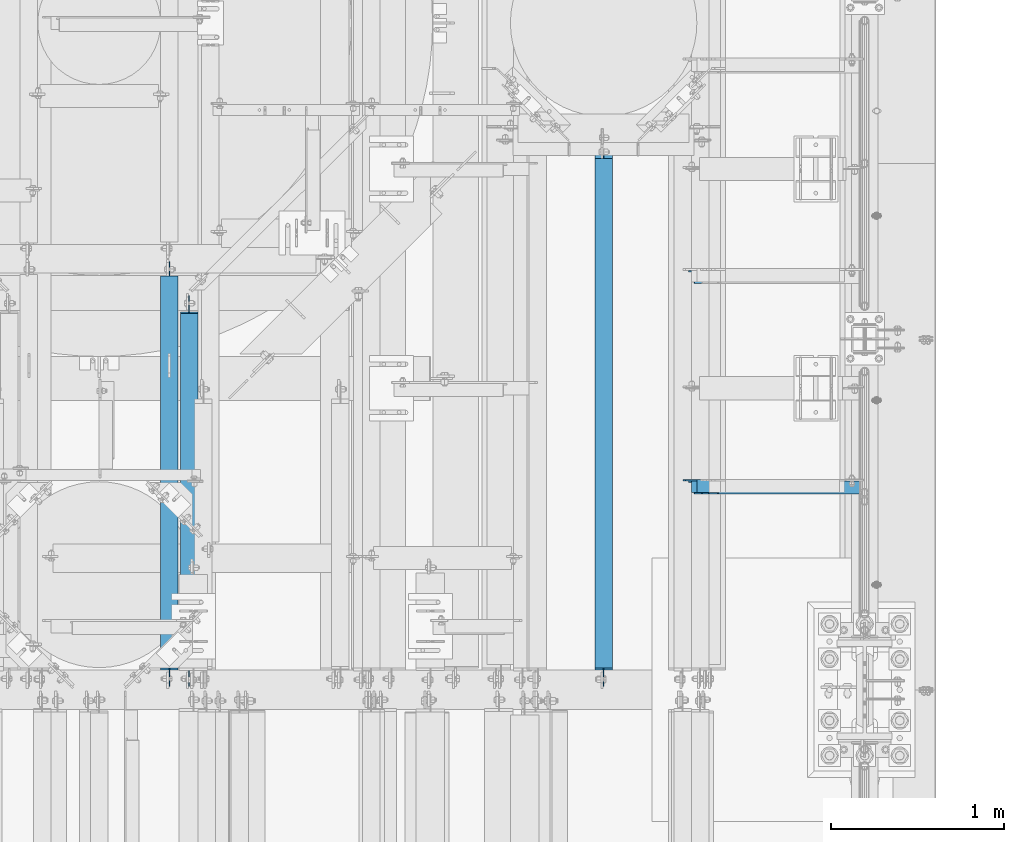
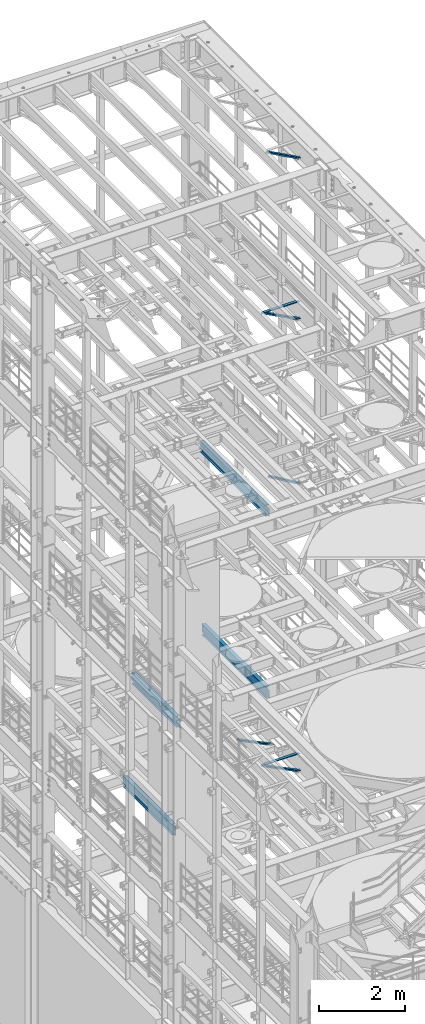
# One storey, part 1047 of 1876: 6 beams, 5 members, 11 elements without a shape of their own.
"""IFC2X3 building model written with IfcOpenShell, lengths in millimetres."""

from ifc_helpers import new_model, si_unit, frame, origin_with_axes, place, context, subcontext, project, spatial, faceted_brep, material, type_object, element, aggregate, save


model = new_model("IFC2X3")

# Units and contexts
model_context = context("Model", 3, precision=1e-05, world=origin_with_axes())
body_context = subcontext(model_context, "Body", "Model", "MODEL_VIEW")
ifc_project = project(units=[si_unit("LENGTHUNIT", "METRE", prefix="MILLI"), si_unit("AREAUNIT", "SQUARE_METRE"), si_unit("VOLUMEUNIT", "CUBIC_METRE"), si_unit("MASSUNIT", "GRAM", prefix="KILO"), si_unit("TIMEUNIT", "SECOND"), si_unit("PLANEANGLEUNIT", "RADIAN"), si_unit("SOLIDANGLEUNIT", "STERADIAN"), si_unit("THERMODYNAMICTEMPERATUREUNIT", "DEGREE_CELSIUS"), si_unit("LUMINOUSINTENSITYUNIT", "LUMEN")], contexts=[model_context])

# Site, building, storey
site_placement = place(None, origin_with_axes())
site = spatial("IfcSite", under=ifc_project, at=site_placement, CompositionType="ELEMENT")
building_placement = place(site_placement, origin_with_axes())
building = spatial("IfcBuilding", under=site, at=building_placement, Name="Undefined", CompositionType="ELEMENT")
storey_placement = place(building_placement, origin_with_axes())
storey = spatial("IfcBuildingStorey", under=building, at=storey_placement, Name="Undefined", CompositionType="ELEMENT", Elevation=0.0)

# Assembly, member
assembly_1_placement = place(storey_placement, origin_with_axes())
assembly_1 = element("IfcElementAssembly", 1, at=assembly_1_placement, inside=storey, AssemblyPlace="NOTDEFINED", PredefinedType="RIGID_FRAME")
ifc_material_1 = material(Name="STEEL/A36")
member_type = type_object("IfcMemberType", Name="L3X3X3/8", PredefinedType="NOTDEFINED")
member_1_placement = place(assembly_1_placement, frame((6546.00359127146, 8791.575, 5110.24886127725), z_axis=(0.0, -1.0, 0.0), x_axis=(0.894904191539842, 0.0, -0.446258319770535)))
member_1 = element("IfcMember", 2, at=member_1_placement, type_object=member_type, material=ifc_material_1, ObjectType="L3X3X3/8", context=body_context, shape_type="Brep", body=[
    faceted_brep([(80.1547206858395, 38.100000000054, -38.1000000000004), (80.1547206858395, 38.100000000054, 38.1000000000004), (1158.95112186373, 38.1000000006807, 38.1000000000004), (1158.95112186373, 38.1000000006807, -38.1000000000004), (80.1547206858399, 28.5750000000526, 38.1000000000004), (1158.95112186373, 28.5750000006792, 38.1000000000004), (80.1547206858399, 28.5750000000526, -28.5750000000007), (1158.95112186373, 28.5750000006792, -28.5750000000007), (80.154720685839, -38.0999999999594, -28.5750000000007), (1158.95112186373, -38.0999999993337, -28.5750000000007), (80.154720685839, -38.0999999999594, -38.1000000000004), (1158.95112186373, -38.0999999993337, -38.1000000000004)], [[[0, 1, 2, 3]], [[1, 4, 5, 2]], [[4, 6, 7, 5]], [[6, 8, 9, 7]], [[8, 10, 11, 9]], [[10, 0, 3, 11]], [[5, 7, 9, 11, 3, 2]], [[10, 8, 6, 4, 1, 0]]]),
])
aggregate(assembly_1, [member_1])

assembly_2_placement = place(storey_placement, origin_with_axes())
assembly_2 = element("IfcElementAssembly", 3, at=assembly_2_placement, inside=storey, AssemblyPlace="NOTDEFINED", PredefinedType="RIGID_FRAME")
member_2_placement = place(assembly_2_placement, frame((6546.00359127146, 10010.775, 5110.24886127725), z_axis=(0.0, -1.0, 0.0), x_axis=(0.894904191539842, 0.0, -0.446258319770535)))
member_2 = element("IfcMember", 4, at=member_2_placement, type_object=member_type, material=ifc_material_1, ObjectType="L3X3X3/8", context=body_context, shape_type="Brep", body=[
    faceted_brep([(80.1547206858395, 38.100000000054, -38.1000000000004), (80.1547206858395, 38.100000000054, 38.1000000000004), (1158.95112186373, 38.1000000006807, 38.1000000000004), (1158.95112186373, 38.1000000006807, -38.1000000000004), (80.1547206858399, 28.5750000000526, 38.1000000000004), (1158.95112186373, 28.5750000006792, 38.1000000000004), (80.1547206858399, 28.5750000000526, -28.5750000000007), (1158.95112186373, 28.5750000006792, -28.5750000000007), (80.154720685839, -38.0999999999594, -28.5750000000007), (1158.95112186373, -38.0999999993337, -28.5750000000007), (80.154720685839, -38.0999999999594, -38.1000000000004), (1158.95112186373, -38.0999999993337, -38.1000000000004)], [[[0, 1, 2, 3]], [[1, 4, 5, 2]], [[4, 6, 7, 5]], [[6, 8, 9, 7]], [[8, 10, 11, 9]], [[10, 0, 3, 11]], [[5, 7, 9, 11, 3, 2]], [[10, 8, 6, 4, 1, 0]]]),
])
aggregate(assembly_2, [member_2])

assembly_3_placement = place(storey_placement, origin_with_axes())
assembly_3 = element("IfcElementAssembly", 5, at=assembly_3_placement, inside=storey, Name="BRACE", AssemblyPlace="NOTDEFINED", PredefinedType="RIGID_FRAME")
member_3_placement = place(assembly_3_placement, frame((6673.56288393271, 8791.575, 13302.1718727092), z_axis=(0.0, -1.0, 0.0), x_axis=(0.861630637805759, 0.0, -0.507535854885584)))
member_3 = element("IfcMember", 6, at=member_3_placement, type_object=member_type, material=ifc_material_1, Name="BRACE", ObjectType="L3X3X3/8", context=body_context, shape_type="Brep", body=[
    faceted_brep([(93.8357350541173, 38.0999999999913, -38.0999999999999), (93.8357350541173, 38.0999999999913, 38.0999999999999), (1052.95263444459, 38.0999999997257, 38.0999999999999), (1052.95263444459, 38.0999999997257, -38.0999999999999), (93.8357350541228, 28.5749999999862, 38.0999999999999), (1052.95263444459, 28.5749999997206, 38.0999999999999), (93.8357350541228, 28.5749999999862, -28.5749999999998), (1052.95263444459, 28.5749999997206, -28.5749999999998), (93.8357350541537, -38.100000000044, -28.5749999999998), (1052.95263444462, -38.100000000306, -28.5749999999998), (93.8357350541537, -38.100000000044, -38.0999999999999), (1052.95263444462, -38.100000000306, -38.0999999999999)], [[[0, 1, 2, 3]], [[1, 4, 5, 2]], [[4, 6, 7, 5]], [[6, 8, 9, 7]], [[8, 10, 11, 9]], [[10, 0, 3, 11]], [[5, 7, 9, 11, 3, 2]], [[10, 8, 6, 4, 1, 0]]]),
])
aggregate(assembly_3, [member_3])

assembly_4_placement = place(storey_placement, origin_with_axes())
assembly_4 = element("IfcElementAssembly", 7, at=assembly_4_placement, inside=storey, AssemblyPlace="NOTDEFINED", PredefinedType="RIGID_FRAME")
member_4_placement = place(assembly_4_placement, frame((6649.22451200342, 8791.575, 22521.7692276093), z_axis=(0.0, -1.0, 0.0), x_axis=(0.877448093107094, 0.0, -0.479671600058544)))
member_4 = element("IfcMember", 8, at=member_4_placement, type_object=member_type, material=ifc_material_1, ObjectType="L3X3X3/8", context=body_context, shape_type="Brep", body=[
    faceted_brep([(59.7482362440578, 38.0999999998749, -38.0999999999999), (59.7482362440578, 38.0999999998749, 38.0999999999999), (1062.91900040893, 38.0999999984488, 38.0999999999999), (1062.91900040893, 38.0999999984488, -38.0999999999999), (59.7482362440696, 28.5749999998843, 38.0999999999999), (1062.91900040895, 28.5749999984582, 38.0999999999999), (59.7482362440696, 28.5749999998843, -28.5749999999998), (1062.91900040895, 28.5749999984582, -28.5749999999998), (59.7482362441442, -38.1000000000495, -28.5749999999998), (1062.91900040902, -38.1000000014719, -28.5749999999998), (59.7482362441442, -38.1000000000495, -38.0999999999999), (1062.91900040902, -38.1000000014719, -38.0999999999999)], [[[0, 1, 2, 3]], [[1, 4, 5, 2]], [[4, 6, 7, 5]], [[6, 8, 9, 7]], [[8, 10, 11, 9]], [[10, 0, 3, 11]], [[5, 7, 9, 11, 3, 2]], [[10, 8, 6, 4, 1, 0]]]),
])
aggregate(assembly_4, [member_4])

assembly_5_placement = place(storey_placement, origin_with_axes())
assembly_5 = element("IfcElementAssembly", 9, at=assembly_5_placement, inside=storey, AssemblyPlace="NOTDEFINED", PredefinedType="RIGID_FRAME")
member_5_placement = place(assembly_5_placement, frame((6548.05484608427, 8791.575, 17987.6375508032), z_axis=(0.0, -1.0, 0.0), x_axis=(0.883528850284789, 0.0, -0.46837674015096)))
member_5 = element("IfcMember", 10, at=member_5_placement, type_object=member_type, material=ifc_material_1, ObjectType="L3X3X3/8", context=body_context, shape_type="Brep", body=[
    faceted_brep([(128.795891913077, 38.1000000000095, -38.0999999999999), (128.795891913077, 38.1000000000095, 38.0999999999999), (1170.59703232476, 38.0999999999913, 38.0999999999999), (1170.59703232476, 38.0999999999913, -38.0999999999999), (128.795891913076, 28.575000000008, 38.0999999999999), (1170.59703232476, 28.5749999999898, 38.0999999999999), (128.795891913076, 28.575000000008, -28.5749999999998), (1170.59703232476, 28.5749999999898, -28.5749999999998), (128.79589191308, -38.1000000000167, -28.5749999999998), (1170.59703232476, -38.1000000000313, -28.5749999999998), (128.79589191308, -38.1000000000167, -38.0999999999999), (1170.59703232476, -38.1000000000313, -38.0999999999999)], [[[0, 1, 2, 3]], [[1, 4, 5, 2]], [[4, 6, 7, 5]], [[6, 8, 9, 7]], [[8, 10, 11, 9]], [[10, 0, 3, 11]], [[5, 7, 9, 11, 3, 2]], [[10, 8, 6, 4, 1, 0]]]),
])
aggregate(assembly_5, [member_5])

# Assembly, beam
assembly_6_placement = place(storey_placement, origin_with_axes())
assembly_6 = element("IfcElementAssembly", 11, at=assembly_6_placement, inside=storey, Name="ANGLE", AssemblyPlace="NOTDEFINED", PredefinedType="RIGID_FRAME")
beam_type_1 = type_object("IfcBeamType", Name="L3X3X3/8", PredefinedType="NOTDEFINED")
beam_1_placement = place(assembly_6_placement, frame((6565.89999988253, 8801.1, 17945.1), z_axis=(0.0, -1.0, 0.0), x_axis=(1.0, 0.0, 0.0)))
beam_1 = element("IfcBeam", 12, at=beam_1_placement, type_object=beam_type_1, material=ifc_material_1, Name="ANGLE", ObjectType="L3X3X3/8", context=body_context, shape_type="Brep", body=[
    faceted_brep([(52.3875000813496, 38.0999999999985, 38.0999999999858), (52.3875000813123, 28.5750001907327, 38.0999999999858), (938.213001286278, 28.5750000000007, 38.0999999999999), (938.213001286278, 38.0999999999985, 38.0999999999999), (52.3875051486311, 28.5750000000007, -28.5750000000144), (938.213000419482, 28.5750000000007, -28.5749999999998), (1015.20625603472, 12.6999992370475, -28.5749999999998), (1015.20625591089, 12.6999992370475, -38.0999999999999), (938.213000295654, 12.6999992370475, -38.0999999999999), (938.213000419482, 12.6999992370475, -28.5749999999998), (938.213000295654, 38.0999999999985, -38.0999999999999), (52.3875058725371, 38.0999999999985, -38.1000000000149), (52.3875058725339, 28.5750001907327, -38.1000000000149), (15.8749999382144, 28.5750001907327, -38.0999999999999), (15.8749936676099, 28.5749999999989, -28.5750000000007), (3.17500012894925, 15.8750003814675, -38.0999999999999), (3.17500032897624, 15.8750003814675, -28.5749999999998), (3.17499999075153, -38.0999999999985, -28.5749999999998), (3.17499999075153, -38.0999999999985, -38.0999999999999), (1046.95625011747, -38.0999999999985, -28.5749999999998), (1046.95625603472, -19.0500007629525, -28.5749999999998), (1046.95625591089, -19.0500007629525, -38.0999999999999), (1046.95625011747, -38.0999999999985, -38.0999999999999)], [[[0, 1, 2, 3]], [[1, 4, 5, 2]], [[6, 7, 8, 9]], [[2, 5, 9, 8, 10, 3]], [[11, 0, 3, 10]], [[1, 0, 11, 12, 4]], [[4, 12, 13, 14]], [[14, 13, 15, 16]], [[17, 16, 15, 18]], [[6, 9, 5, 4, 14, 16, 17, 19, 20]], [[7, 6, 20, 21]], [[18, 15, 13, 12, 11, 10, 8, 7, 21, 22]], [[17, 18, 22, 19]], [[21, 20, 19, 22]]]),
])
aggregate(assembly_6, [beam_1])

assembly_7_placement = place(storey_placement, origin_with_axes())
assembly_7 = element("IfcElementAssembly", 13, at=assembly_7_placement, inside=storey, Name="ANGLE", AssemblyPlace="NOTDEFINED", PredefinedType="RIGID_FRAME")
beam_2_placement = place(assembly_7_placement, frame((6565.9, 8801.1, 5092.7), z_axis=(0.0, -1.0, 0.0), x_axis=(1.0, 0.0, 0.0)))
beam_2 = element("IfcBeam", 14, at=beam_2_placement, type_object=beam_type_1, material=ifc_material_1, Name="ANGLE", ObjectType="L3X3X3/8", context=body_context, shape_type="Brep", body=[
    faceted_brep([(938.213000419482, 28.5750000000007, -28.5749999999998), (938.213001286278, 28.5750000000007, 38.0999999999999), (84.137014014791, 28.5749999999998, 38.1000000000258), (84.1370001605219, 28.5749999999998, -28.5750000000007), (938.213001286278, 38.0999999999985, 38.0999999999999), (84.136999759924, 38.0999999999985, 38.0999999999999), (15.8750004498515, 25.4000000000005, -28.5750000000007), (15.8750002879233, 25.4000000000005, -38.1000000000004), (3.17500047865815, 12.7000001907354, -38.1000000000004), (3.1750006405864, 12.7000001907354, -28.5750000000007), (84.1369986264262, 25.4000000000005, -28.5750000000007), (84.136998464498, 25.4000000000005, -38.1000000000004), (84.1369984645207, 38.0999999999985, -38.0999999999999), (938.213000295654, 38.0999999999985, -38.0999999999999), (938.213000419482, 12.6999992370475, -28.5749999999998), (938.213000295654, 12.6999992370475, -38.0999999999999), (1015.20625603472, 12.6999992370475, -28.5749999999998), (1015.20625591089, 12.6999992370475, -38.0999999999999), (1046.95625603472, -19.0500007629525, -28.5749999999998), (1046.95625591089, -19.0500007629525, -38.0999999999999), (1046.95625011747, -38.0999999999985, -28.5749999999998), (1046.95625011747, -38.0999999999985, -38.0999999999999), (3.17499999075153, -38.0999999999985, -28.5749999999998), (3.17499999075153, -38.0999999999985, -38.0999999999999), (3.17500047865815, -1.52587836055318e-06, -38.1000000000004), (3.1750006405864, -1.52587836055318e-06, -28.5750000000007)], [[[0, 1, 2, 3]], [[1, 4, 5, 2]], [[6, 7, 8, 9]], [[10, 11, 7, 6]], [[2, 5, 12, 11, 10, 3]], [[4, 13, 12, 5]], [[1, 0, 14, 15, 13, 4]], [[16, 17, 15, 14]], [[17, 16, 18, 19]], [[19, 18, 20, 21]], [[22, 23, 21, 20]], [[8, 7, 11, 12, 13, 15, 17, 19, 21, 23, 24]], [[9, 8, 24, 25]], [[20, 18, 16, 14, 0, 3, 10, 6, 9, 25, 22]], [[24, 23, 22, 25]]]),
])
aggregate(assembly_7, [beam_2])

assembly_8_placement = place(storey_placement, origin_with_axes())
assembly_8 = element("IfcElementAssembly", 15, at=assembly_8_placement, inside=storey, Name="BEAM", AssemblyPlace="NOTDEFINED", PredefinedType="RIGID_FRAME")
ifc_material_2 = material(Name="STEEL/A992")
beam_type_2 = type_object("IfcBeamType", Name="W12X16", PredefinedType="NOTDEFINED")
beam_3_placement = place(assembly_8_placement, frame((6108.7, 7620.0, 13157.2), z_axis=(0.0, 0.0, 1.0), x_axis=(0.0, 1.0, 0.0)))
beam_3 = element("IfcBeam", 16, at=beam_3_placement, type_object=beam_type_2, material=ifc_material_2, Name="BEAM", ObjectType="W12X16", context=body_context, shape_type="Brep", body=[
    faceted_brep([(3152.72210652151, -3.17500000000018, -146.049999999999), (3152.72210652151, -50.8000000000002, -146.049999999999), (3152.72210652151, -50.8000000000002, -152.4), (3152.72210652151, 50.8000000000002, -152.4), (3152.72210652151, 50.8000000000002, -146.049999999999), (3152.72210652151, 3.17500000000018, -146.049999999999), (3152.72210652151, 3.17500000000018, -133.349999809263), (3152.72210652151, -3.17500000000018, -133.349999809263), (3153.6888364441, 3.17500000000018, -128.489920291217), (3153.6888364441, -3.17500000000018, -128.489920291217), (3156.44185034457, 3.17500000000018, -124.369743823063), (3156.44185034457, -3.17500000000018, -124.369743823063), (3160.56202681273, 3.17500000000018, -121.616729922585), (3160.56202681273, -3.17500000000018, -121.616729922585), (3165.42210633077, 3.17500000000018, -120.649999999998), (3165.42210633077, -3.17500000000018, -120.649999999998), (3235.27210652151, -3.17500000000018, -120.649999999998), (3235.27210652151, 3.17500000000018, -120.649999999998), (134.14375, 3.17500000000018, 146.049999999999), (134.14375, 50.8000000000002, 146.049999999999), (3152.72210652151, 50.8000000000002, 146.049999999999), (3152.72210652151, 3.17500000000018, 146.049999999999), (121.44375, -3.17500000000018, -139.699999809265), (121.44375, 3.17500000000018, -139.699999809265), (121.44375, 3.17500000000018, -146.049999999999), (121.44375, 50.8000000000002, -146.049999999999), (121.44375, 50.8000000000002, -152.4), (121.44375, -50.8000000000002, -152.4), (121.44375, -50.8000000000002, -146.049999999999), (121.44375, -3.17500000000018, -146.049999999999), (120.477020077413, -3.17500000000018, -134.839920291219), (120.477020077413, 3.17500000000018, -134.839920291219), (117.724006176934, -3.17500000000018, -130.719743823065), (117.724006176934, 3.17500000000018, -130.719743823065), (113.603829708781, -3.17500000000018, -127.966729922588), (113.603829708781, 3.17500000000018, -127.966729922588), (108.743750190735, -3.17500000000018, -127.0), (108.743750190735, 3.17500000000018, -127.0), (19.84375, -3.17499999999995, -126.999999999996), (19.84375, 3.17499999999995, -126.999999999996), (19.84375, -3.17500000000018, 114.299999999999), (19.84375, 3.17500000000018, 114.299999999999), (121.443750190735, -3.17500000000018, 114.299999999999), (121.443750190735, 3.17500000000018, 114.299999999999), (126.303829708781, -3.17500000000018, 115.266729922587), (126.303829708781, 3.17500000000018, 115.266729922587), (130.424006176934, -3.17500000000018, 118.019743823064), (130.424006176934, 3.17500000000018, 118.019743823064), (133.177020077413, -3.17500000000018, 122.139920291218), (133.177020077413, 3.17500000000018, 122.139920291218), (134.14375, -3.17500000000018, 126.999999809264), (134.14375, 3.17500000000018, 126.999999809264), (134.14375, -50.8000000000002, 152.4), (134.14375, 50.8000000000002, 152.4), (134.14375, -3.17500000000018, 146.049999999999), (134.14375, -50.8000000000002, 146.049999999999), (3152.72210652151, -3.17500000000018, 146.049999999999), (3152.72210652151, -50.8000000000002, 146.049999999999), (3152.72210652151, -50.8000000000002, 152.4), (3152.72210652151, 50.8000000000002, 152.4), (3152.72210652151, -3.17500000000018, 133.349999809267), (3152.72210652151, 3.17500000000018, 133.349999809267), (3153.6888364441, -3.17500000000018, 128.48992029122), (3153.6888364441, 3.17500000000018, 128.48992029122), (3156.44185034457, -3.17500000000018, 124.369743823067), (3156.44185034457, 3.17500000000018, 124.369743823067), (3160.56202681273, -3.17500000000018, 121.616729922589), (3160.56202681273, 3.17500000000018, 121.616729922589), (3165.42210633077, -3.17500000000018, 120.650000000001), (3165.42210633077, 3.17500000000018, 120.650000000001), (3235.27210652151, -3.17500000000018, 120.650000000001), (3235.27210652151, 3.17500000000018, 120.650000000001)], [[[0, 1, 2, 3, 4, 5, 6, 7]], [[7, 6, 8, 9]], [[9, 8, 10, 11]], [[11, 10, 12, 13]], [[13, 12, 14, 15]], [[16, 15, 14, 17]], [[18, 19, 20, 21]], [[22, 23, 24, 25, 26, 27, 28, 29]], [[30, 31, 23, 22]], [[32, 33, 31, 30]], [[34, 35, 33, 32]], [[36, 37, 35, 34]], [[38, 39, 37, 36]], [[40, 41, 39, 38]], [[42, 43, 41, 40]], [[44, 45, 43, 42]], [[46, 47, 45, 44]], [[48, 49, 47, 46]], [[50, 51, 49, 48]], [[52, 53, 19, 18, 51, 50, 54, 55]], [[55, 54, 56, 57]], [[52, 55, 57, 58]], [[53, 52, 58, 59]], [[19, 53, 59, 20]], [[58, 57, 56, 60, 61, 21, 20, 59]], [[62, 63, 61, 60]], [[64, 65, 63, 62]], [[66, 67, 65, 64]], [[68, 69, 67, 66]], [[70, 71, 69, 68]], [[71, 70, 16, 17]], [[12, 10, 8, 6, 5, 24, 23, 31, 33, 35, 37, 39, 41, 43, 45, 47, 49, 51, 18, 21, 61, 63, 65, 67, 69, 71, 17, 14]], [[25, 24, 5, 4]], [[26, 25, 4, 3]], [[27, 26, 3, 2]], [[28, 27, 2, 1]], [[29, 28, 1, 0]], [[70, 68, 66, 64, 62, 60, 56, 54, 50, 48, 46, 44, 42, 40, 38, 36, 34, 32, 30, 22, 29, 0, 7, 9, 11, 13, 15, 16]]]),
])
aggregate(assembly_8, [beam_3])

assembly_9_placement = place(storey_placement, origin_with_axes())
assembly_9 = element("IfcElementAssembly", 17, at=assembly_9_placement, inside=storey, Name="BEAM", AssemblyPlace="NOTDEFINED", PredefinedType="RIGID_FRAME")
beam_4_placement = place(assembly_9_placement, frame((6108.7, 7620.0, 8001.0), z_axis=(0.0, 0.0, 1.0), x_axis=(0.0, 1.0, 0.0)))
beam_4 = element("IfcBeam", 18, at=beam_4_placement, type_object=beam_type_2, material=ifc_material_2, Name="BEAM", ObjectType="W12X16", context=body_context, shape_type="Brep", body=[
    faceted_brep([(3076.575, -3.17500000000018, -146.05), (3076.575, -50.8000000000002, -146.05), (3076.575, -50.8000000000002, -152.4), (3076.575, 50.8000000000002, -152.4), (3076.575, 50.8000000000002, -146.05), (3076.575, 3.17500000000018, -146.05), (3076.575, 3.17500000000018, -133.349999809266), (3076.575, -3.17500000000018, -133.349999809266), (3077.54172992259, 3.17500000000018, -128.48992029122), (3077.54172992259, -3.17500000000018, -128.48992029122), (3080.29474382307, 3.17500000000018, -124.369743823067), (3080.29474382307, -3.17500000000018, -124.369743823067), (3084.41492029122, 3.17500000000018, -121.616729922588), (3084.41492029122, -3.17500000000018, -121.616729922588), (3089.27499980927, 3.17500000000018, -120.650000000001), (3089.27499980927, -3.17500000000018, -120.650000000001), (3159.125, -3.17500000000018, -120.650000000001), (3159.125, 3.17500000000018, -120.650000000001), (127.79375, 3.17500000000018, 146.05), (127.79375, 50.8000000000002, 146.05), (3076.575, 50.8000000000002, 146.05), (3076.575, 3.17500000000018, 146.05), (115.09375, -3.17500000000018, -139.699999809266), (115.09375, 3.17500000000018, -139.699999809266), (115.09375, 3.17500000000018, -146.05), (115.09375, 50.8000000000002, -146.05), (115.09375, 50.8000000000002, -152.4), (115.09375, -50.8000000000002, -152.4), (115.09375, -50.8000000000002, -146.05), (115.09375, -3.17500000000018, -146.05), (114.127020077412, -3.17500000000018, -134.839920291221), (114.127020077412, 3.17500000000018, -134.839920291221), (111.374006176934, -3.17500000000018, -130.719743823067), (111.374006176934, 3.17500000000018, -130.719743823067), (107.25382970878, -3.17500000000018, -127.966729922588), (107.25382970878, 3.17500000000018, -127.966729922588), (102.393750190735, -3.17500000000018, -127.000000000001), (102.393750190735, 3.17500000000018, -127.000000000001), (19.84375, -3.17499999999995, -126.999999999996), (19.84375, 3.17499999999995, -126.999999999996), (19.84375, -3.17500000000018, 114.299999999999), (19.84375, 3.17500000000018, 114.299999999999), (115.093750190735, -3.17500000000018, 114.299999999999), (115.093750190735, 3.17500000000018, 114.299999999999), (119.95382970878, -3.17500000000018, 115.266729922587), (119.95382970878, 3.17500000000018, 115.266729922587), (124.074006176934, -3.17500000000018, 118.019743823065), (124.074006176934, 3.17500000000018, 118.019743823065), (126.827020077412, -3.17500000000018, 122.139920291219), (126.827020077412, 3.17500000000018, 122.139920291219), (127.79375, -3.17500000000018, 126.999999809264), (127.79375, 3.17500000000018, 126.999999809264), (127.79375, -50.8000000000002, 152.4), (127.79375, 50.8000000000002, 152.4), (127.79375, -3.17500000000018, 146.05), (127.79375, -50.8000000000002, 146.05), (3076.575, -3.17500000000018, 146.05), (3076.575, -50.8000000000002, 146.05), (3076.575, -50.8000000000002, 152.4), (3076.575, 50.8000000000002, 152.4), (3076.575, -3.17500000000018, 133.349999809265), (3076.575, 3.17500000000018, 133.349999809265), (3077.54172992259, -3.17500000000018, 128.489920291219), (3077.54172992259, 3.17500000000018, 128.489920291219), (3080.29474382307, -3.17500000000018, 124.369743823066), (3080.29474382307, 3.17500000000018, 124.369743823066), (3084.41492029122, -3.17500000000018, 121.616729922587), (3084.41492029122, 3.17500000000018, 121.616729922587), (3089.27499980927, -3.17500000000018, 120.65), (3089.27499980927, 3.17500000000018, 120.65), (3159.125, -3.17500000000018, 120.65), (3159.125, 3.17500000000018, 120.65)], [[[0, 1, 2, 3, 4, 5, 6, 7]], [[7, 6, 8, 9]], [[9, 8, 10, 11]], [[11, 10, 12, 13]], [[13, 12, 14, 15]], [[16, 15, 14, 17]], [[18, 19, 20, 21]], [[22, 23, 24, 25, 26, 27, 28, 29]], [[30, 31, 23, 22]], [[32, 33, 31, 30]], [[34, 35, 33, 32]], [[36, 37, 35, 34]], [[38, 39, 37, 36]], [[40, 41, 39, 38]], [[42, 43, 41, 40]], [[44, 45, 43, 42]], [[46, 47, 45, 44]], [[48, 49, 47, 46]], [[50, 51, 49, 48]], [[52, 53, 19, 18, 51, 50, 54, 55]], [[55, 54, 56, 57]], [[52, 55, 57, 58]], [[53, 52, 58, 59]], [[19, 53, 59, 20]], [[58, 57, 56, 60, 61, 21, 20, 59]], [[62, 63, 61, 60]], [[64, 65, 63, 62]], [[66, 67, 65, 64]], [[68, 69, 67, 66]], [[70, 71, 69, 68]], [[71, 70, 16, 17]], [[12, 10, 8, 6, 5, 24, 23, 31, 33, 35, 37, 39, 41, 43, 45, 47, 49, 51, 18, 21, 61, 63, 65, 67, 69, 71, 17, 14]], [[25, 24, 5, 4]], [[26, 25, 4, 3]], [[27, 26, 3, 2]], [[28, 27, 2, 1]], [[29, 28, 1, 0]], [[70, 68, 66, 64, 62, 60, 56, 54, 50, 48, 46, 44, 42, 40, 38, 36, 34, 32, 30, 22, 29, 0, 7, 9, 11, 13, 15, 16]]]),
])
aggregate(assembly_9, [beam_4])

assembly_10_placement = place(storey_placement, origin_with_axes())
assembly_10 = element("IfcElementAssembly", 19, at=assembly_10_placement, inside=storey, Name="BEAM", AssemblyPlace="NOTDEFINED", PredefinedType="RIGID_FRAME")
beam_5_placement = place(assembly_10_placement, frame((3708.4, 7620.0, 8001.0), z_axis=(0.0, 0.0, 1.0), x_axis=(0.0, 1.0, 0.0)))
beam_5 = element("IfcBeam", 20, at=beam_5_placement, type_object=beam_type_2, material=ifc_material_2, Name="BEAM", ObjectType="W12X16", context=body_context, shape_type="Brep", body=[
    faceted_brep([(19.84375, -3.17499999999995, -126.999999999996), (19.84375, 3.17499999999995, -126.999999999996), (102.393750190735, 3.17500000000018, -127.000000000001), (102.393750190735, -3.17500000000018, -127.000000000001), (107.25382970878, 3.17500000000018, -127.966729922588), (107.25382970878, -3.17500000000018, -127.966729922588), (111.374006176934, 3.17500000000018, -130.719743823067), (111.374006176934, -3.17500000000018, -130.719743823067), (114.127020077412, 3.17500000000018, -134.839920291221), (114.127020077412, -3.17500000000018, -134.839920291221), (115.09375, -3.17500000000018, -139.699999809266), (115.09375, 3.17500000000018, -139.699999809266), (115.09375, 3.17500000000018, -146.05), (115.09375, 50.8000000000002, -146.05), (115.09375, 50.8000000000002, -152.4), (115.09375, -50.8000000000002, -152.4), (115.09375, -50.8000000000002, -146.05), (115.09375, -3.17500000000018, -146.05), (2180.43124999999, 50.8000000000002, 146.05), (2180.43124999999, 3.17500000000018, 146.05), (127.79375, 3.17500000000018, 146.05), (127.79375, 50.8000000000002, 146.05), (115.093750190735, -3.17500000000018, 114.299999999999), (115.093750190735, 3.17500000000018, 114.299999999999), (19.84375, 3.17500000000018, 114.299999999999), (19.84375, -3.17500000000018, 114.299999999999), (119.95382970878, -3.17500000000018, 115.266729922587), (119.95382970878, 3.17500000000018, 115.266729922587), (124.074006176934, -3.17500000000018, 118.019743823065), (124.074006176934, 3.17500000000018, 118.019743823065), (126.827020077412, -3.17500000000018, 122.139920291219), (126.827020077412, 3.17500000000018, 122.139920291219), (127.79375, -3.17500000000018, 126.999999809264), (127.79375, 3.17500000000018, 126.999999809264), (2180.43124999999, -50.8000000000002, 152.4), (2180.43124999999, 50.8000000000002, 152.4), (127.79375, 50.8000000000002, 152.4), (127.79375, -50.8000000000002, 152.4), (2180.43124999999, -50.8000000000002, 146.05), (127.79375, -50.8000000000002, 146.05), (2180.43124999999, -3.17500000000018, 146.05), (127.79375, -3.17500000000018, 146.05), (2180.43124999999, -3.17500000000018, 139.699999809265), (2180.43124999999, 3.17500000000018, 139.699999809265), (2181.39797992258, -3.17500000000018, 134.83992029122), (2181.39797992258, 3.17500000000018, 134.83992029122), (2184.15099382306, -3.17500000000018, 130.719743823066), (2184.15099382306, 3.17500000000018, 130.719743823066), (2188.27117029121, -3.17500000000018, 127.966729922588), (2188.27117029121, 3.17500000000018, 127.966729922588), (2193.13124980926, -3.17500000000018, 127.0), (2193.13124980926, 3.17500000000018, 127.0), (2282.03125, -3.17500000000018, 127.0), (2282.03125, 3.17500000000018, 127.0), (2282.03125, -3.17500000000018, -127.0), (2282.03125, 3.17500000000018, -127.0), (2199.48124980926, -3.17500000000018, -127.0), (2199.48124980926, 3.17500000000018, -127.0), (2194.62117029122, -3.17500000000018, -127.966729922588), (2194.62117029122, 3.17500000000018, -127.966729922588), (2190.50099382306, -3.17500000000018, -130.719743823066), (2190.50099382306, 3.17500000000018, -130.719743823066), (2187.74797992258, -3.17500000000018, -134.83992029122), (2187.74797992258, 3.17500000000018, -134.83992029122), (2186.78124999999, -3.17500000000018, -139.699999809265), (2186.78124999999, 3.17500000000018, -139.699999809265), (2186.78124999999, -3.17500000000018, -146.05), (2186.78124999999, -50.8000000000002, -146.05), (2186.78124999999, -50.8000000000002, -152.4), (2186.78124999999, 50.8000000000002, -152.4), (2186.78124999999, 50.8000000000002, -146.05), (2186.78124999999, 3.17500000000018, -146.05)], [[[0, 1, 2, 3]], [[3, 2, 4, 5]], [[5, 4, 6, 7]], [[7, 6, 8, 9]], [[10, 11, 12, 13, 14, 15, 16, 17]], [[9, 8, 11, 10]], [[18, 19, 20, 21]], [[22, 23, 24, 25]], [[26, 27, 23, 22]], [[28, 29, 27, 26]], [[30, 31, 29, 28]], [[32, 33, 31, 30]], [[34, 35, 36, 37]], [[38, 34, 37, 39]], [[40, 38, 39, 41]], [[37, 36, 21, 20, 33, 32, 41, 39]], [[35, 18, 21, 36]], [[34, 38, 40, 42, 43, 19, 18, 35]], [[44, 45, 43, 42]], [[46, 47, 45, 44]], [[48, 49, 47, 46]], [[50, 51, 49, 48]], [[52, 53, 51, 50]], [[53, 52, 54, 55]], [[54, 56, 57, 55]], [[58, 59, 57, 56]], [[60, 61, 59, 58]], [[62, 63, 61, 60]], [[64, 65, 63, 62]], [[66, 67, 68, 69, 70, 71, 65, 64]], [[67, 66, 17, 16]], [[68, 67, 16, 15]], [[69, 68, 15, 14]], [[70, 69, 14, 13]], [[71, 70, 13, 12]], [[6, 4, 2, 1, 24, 23, 27, 29, 31, 33, 20, 19, 43, 45, 47, 49, 51, 53, 55, 57, 59, 61, 63, 65, 71, 12, 11, 8]], [[25, 24, 1, 0]], [[66, 64, 62, 60, 58, 56, 54, 52, 50, 48, 46, 44, 42, 40, 41, 32, 30, 28, 26, 22, 25, 0, 3, 5, 7, 9, 10, 17]]]),
])
aggregate(assembly_10, [beam_5])

assembly_11_placement = place(storey_placement, origin_with_axes())
assembly_11 = element("IfcElementAssembly", 21, at=assembly_11_placement, inside=storey, Name="BEAM", AssemblyPlace="NOTDEFINED", PredefinedType="RIGID_FRAME")
beam_6_placement = place(assembly_11_placement, frame((3594.1, 7731.125, 4978.4), z_axis=(0.0, 0.0, 1.0), x_axis=(0.0, 1.0, 0.0)))
beam_6 = element("IfcBeam", 22, at=beam_6_placement, type_object=beam_type_2, material=ifc_material_2, Name="BEAM", ObjectType="W12X16", context=body_context, shape_type="Brep", body=[
    faceted_brep([(2273.3, -3.17500000000018, -146.05), (2273.3, -50.8000000000002, -146.05), (2273.3, -50.8000000000002, -152.4), (2273.3, 50.8000000000002, -152.4), (2273.3, 50.8000000000002, -146.05), (2273.3, 3.17500000000018, -146.05), (2273.3, 3.17500000000018, -139.699999809264), (2273.3, -3.17500000000018, -139.699999809264), (2274.26672992259, 3.17500000000018, -134.839920291219), (2274.26672992259, -3.17500000000018, -134.839920291219), (2277.01974382306, 3.17500000000018, -130.719743823065), (2277.01974382306, -3.17500000000018, -130.719743823065), (2281.13992029122, 3.17500000000018, -127.966729922587), (2281.13992029122, -3.17500000000018, -127.966729922587), (2285.99999980926, 3.17500000000018, -126.999999999999), (2285.99999980926, -3.17500000000018, -126.999999999999), (2368.55, -3.17500000000018, -126.999999999999), (2368.55, 3.17500000000018, -126.999999999999), (16.6687499999998, 3.17500000000018, 146.05), (16.6687499999998, 50.8000000000002, 146.05), (2286.0, 50.8000000000002, 146.05), (2286.0, 3.17500000000018, 146.05), (3.96875, -3.17500000000018, -139.699999809266), (3.96875, 3.17500000000018, -139.699999809266), (3.96875, 3.17500000000018, -146.05), (3.96875, 50.8000000000002, -146.05), (3.96875, 50.8000000000002, -152.4), (3.96875, -50.8000000000002, -152.4), (3.96875, -50.8000000000002, -146.05), (3.96875, -3.17500000000018, -146.05), (3.00202007741245, -3.17500000000018, -134.839920291221), (3.00202007741245, 3.17500000000018, -134.839920291221), (0.249006176934017, -3.17500000000018, -130.719743823067), (0.249006176934017, 3.17500000000018, -130.719743823067), (-3.87117029121964, -3.17500000000018, -127.966729922588), (-3.87117029121964, 3.17500000000018, -127.966729922588), (-8.73124980926514, -3.17500000000018, -127.000000000001), (-8.73124980926514, 3.17500000000018, -127.000000000001), (-91.28125, -3.17500000000018, -127.000000000001), (-91.28125, 3.17500000000018, -127.000000000001), (-91.28125, -3.17500000000018, 114.299999999999), (-91.28125, 3.17500000000018, 114.299999999999), (3.96875019073468, -3.17500000000018, 114.299999999999), (3.96875019073468, 3.17500000000018, 114.299999999999), (8.82882970878018, -3.17500000000018, 115.266729922587), (8.82882970878018, 3.17500000000018, 115.266729922587), (12.9490061769338, -3.17500000000018, 118.019743823065), (12.9490061769338, 3.17500000000018, 118.019743823065), (15.7020200774123, -3.17500000000018, 122.139920291219), (15.7020200774123, 3.17500000000018, 122.139920291219), (16.6687499999944, -3.17500000000018, 127.0), (16.6687499999944, 3.17500000000018, 127.0), (16.6687499999998, -50.8000000000002, 152.4), (16.6687499999998, 50.8000000000002, 152.4), (16.6687499999998, -3.17500000000018, 146.05), (16.6687499999998, -50.8000000000002, 146.05), (2286.0, -3.17500000000018, 146.05), (2286.0, -50.8000000000002, 146.05), (2286.0, -50.8000000000002, 152.4), (2286.0, 50.8000000000002, 152.4), (2286.0, -3.17500000000018, 139.699999809266), (2286.0, 3.17500000000018, 139.699999809266), (2286.96672992259, -3.17500000000018, 134.839920291221), (2286.96672992259, 3.17500000000018, 134.839920291221), (2289.71974382307, -3.17500000000018, 130.719743823067), (2289.71974382307, 3.17500000000018, 130.719743823067), (2293.83992029122, -3.17500000000018, 127.966729922588), (2293.83992029122, 3.17500000000018, 127.966729922588), (2298.69999980926, -3.17500000000018, 127.000000000001), (2298.69999980926, 3.17500000000018, 127.000000000001), (2368.55, -3.17500000000018, 127.000000000001), (2368.55, 3.17500000000018, 127.000000000001)], [[[0, 1, 2, 3, 4, 5, 6, 7]], [[7, 6, 8, 9]], [[9, 8, 10, 11]], [[11, 10, 12, 13]], [[13, 12, 14, 15]], [[16, 15, 14, 17]], [[18, 19, 20, 21]], [[22, 23, 24, 25, 26, 27, 28, 29]], [[30, 31, 23, 22]], [[32, 33, 31, 30]], [[34, 35, 33, 32]], [[36, 37, 35, 34]], [[38, 39, 37, 36]], [[40, 41, 39, 38]], [[42, 43, 41, 40]], [[44, 45, 43, 42]], [[46, 47, 45, 44]], [[48, 49, 47, 46]], [[50, 51, 49, 48]], [[52, 53, 19, 18, 51, 50, 54, 55]], [[55, 54, 56, 57]], [[52, 55, 57, 58]], [[53, 52, 58, 59]], [[19, 53, 59, 20]], [[58, 57, 56, 60, 61, 21, 20, 59]], [[62, 63, 61, 60]], [[64, 65, 63, 62]], [[66, 67, 65, 64]], [[68, 69, 67, 66]], [[70, 71, 69, 68]], [[71, 70, 16, 17]], [[12, 10, 8, 6, 5, 24, 23, 31, 33, 35, 37, 39, 41, 43, 45, 47, 49, 51, 18, 21, 61, 63, 65, 67, 69, 71, 17, 14]], [[25, 24, 5, 4]], [[26, 25, 4, 3]], [[27, 26, 3, 2]], [[28, 27, 2, 1]], [[29, 28, 1, 0]], [[70, 68, 66, 64, 62, 60, 56, 54, 50, 48, 46, 44, 42, 40, 38, 36, 34, 32, 30, 22, 29, 0, 7, 9, 11, 13, 15, 16]]]),
])
aggregate(assembly_11, [beam_6])

save(model, "model.ifc")
